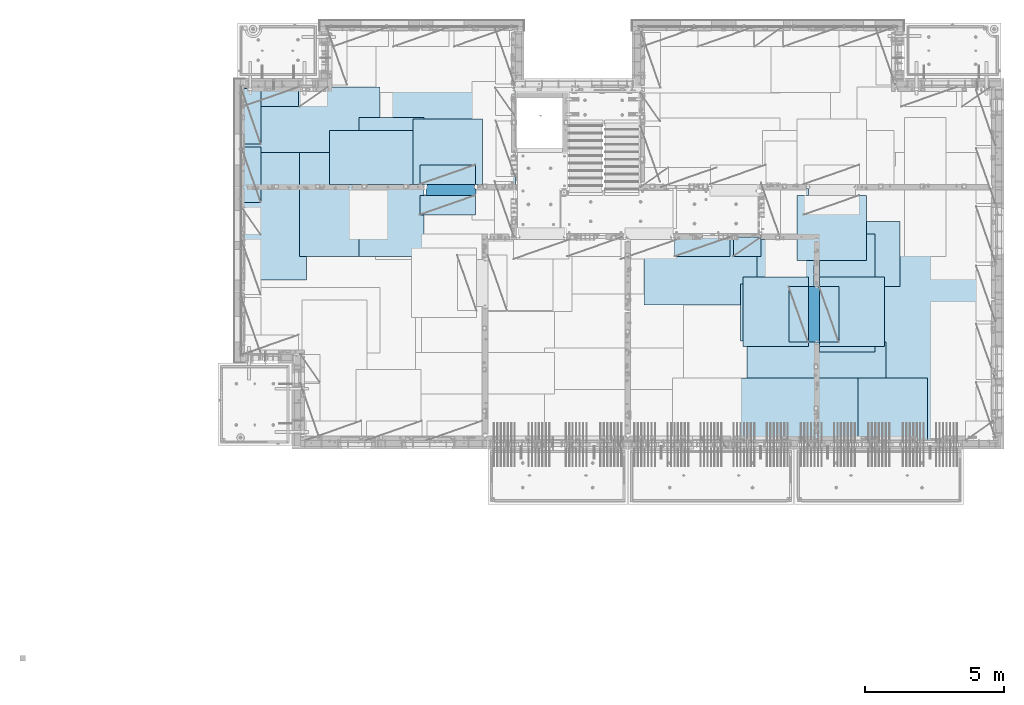
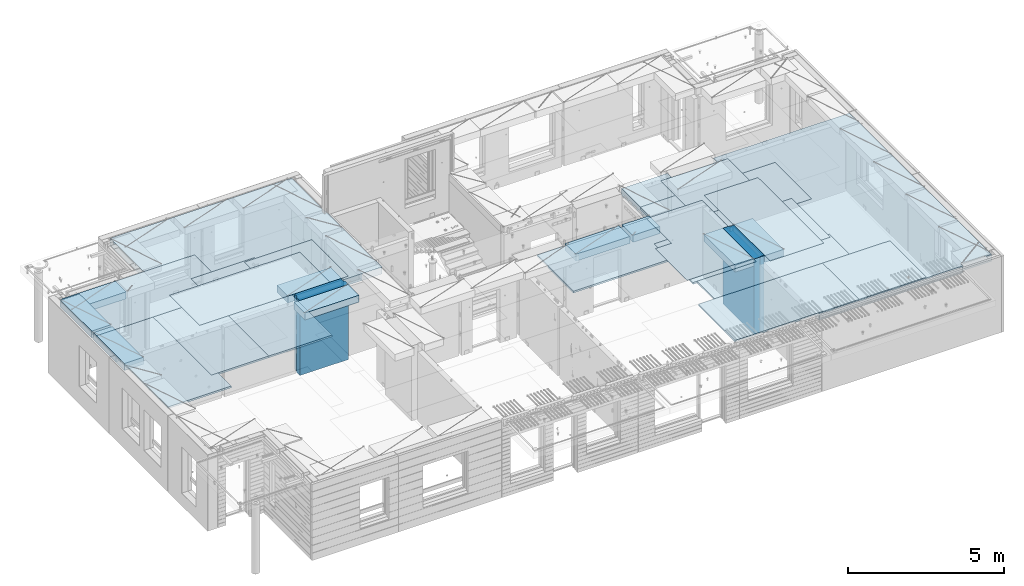
# One storey, part 204 of 349: 27 plates, 2 slabs, 25 elements without a shape of their own.
"""IFC2X3 building model written with IfcOpenShell, lengths in millimetres."""

from ifc_helpers import new_model, si_unit, frame, origin_with_axes, place, context, subcontext, project, spatial, faceted_brep, material, type_object, element, aggregate, save


model = new_model("IFC2X3")

# Units and contexts
model_context = context("Model", 3, precision=1e-05, world=origin_with_axes())
body_context = subcontext(model_context, "Body", "Model", "MODEL_VIEW")
ifc_project = project(units=[si_unit("LENGTHUNIT", "METRE", prefix="MILLI"), si_unit("AREAUNIT", "SQUARE_METRE"), si_unit("VOLUMEUNIT", "CUBIC_METRE"), si_unit("MASSUNIT", "GRAM", prefix="KILO"), si_unit("TIMEUNIT", "SECOND"), si_unit("PLANEANGLEUNIT", "RADIAN"), si_unit("SOLIDANGLEUNIT", "STERADIAN"), si_unit("THERMODYNAMICTEMPERATUREUNIT", "DEGREE_CELSIUS"), si_unit("LUMINOUSINTENSITYUNIT", "LUMEN")], contexts=[model_context])

# Site, building, storey
site_placement = place(None, origin_with_axes())
site = spatial("IfcSite", under=ifc_project, at=site_placement, CompositionType="ELEMENT")
building_placement = place(site_placement, origin_with_axes())
building = spatial("IfcBuilding", under=site, at=building_placement, CompositionType="ELEMENT")
storey_placement = place(building_placement, origin_with_axes())
storey = spatial("IfcBuildingStorey", under=building, at=storey_placement, Name="4", CompositionType="ELEMENT", Elevation=0.0)

# Assembly, slabs
assembly_1_placement = place(storey_placement, origin_with_axes())
assembly_1 = element("IfcElementAssembly", 1, at=assembly_1_placement, inside=storey, AssemblyPlace="NOTDEFINED", PredefinedType="REINFORCEMENT_UNIT")
ifc_material_1 = material(Name="CONCRETE/C30/37")
slab_type_1 = type_object("IfcSlabType", PredefinedType="NOTDEFINED")
slab_1_placement = place(assembly_1_placement, frame((7880.0, 16980.0, 93595.0), z_axis=(0.0, 1.0, 0.0), x_axis=(1.0, 0.0, 0.0)))
slab_1 = element("IfcSlab", 2, at=slab_1_placement, type_object=slab_type_1, material=ifc_material_1, PredefinedType="FLOOR", context=body_context, shape_type="Brep", body=[
    faceted_brep([(6583.68914550781, -135.0, 0.0), (6583.68914550781, 135.0, 0.0), (6583.68914550781, 135.0, 100.0), (6583.68914550781, -135.0, 100.0), (6649.99914550781, -135.0, 99.9997787475586), (6649.99914550781, 135.0, 99.9997787475586), (1.81898940354586e-12, -135.0, 1.81898940354586e-12), (-0.0001220703125, -135.0, 3600.0), (-0.0001220703125, 135.0, 3600.0), (1.81898940354586e-12, 135.0, 1.81898940354586e-12), (3110.00024414063, -135.0, 3600.0), (3110.00024414063, 135.0, 3600.0), (3110.00024414063, -135.0, 5760.0), (3110.00024414063, 135.0, 5760.0), (9850.0009765625, -135.0, 5760.0), (9850.0009765625, 135.0, 5760.0), (9850.0009765625, -135.0, 3600.0), (9850.0009765625, 135.0, 3600.0), (9870.0, -135.0, 3600.0), (9870.0, 135.0, 3600.0), (9870.0, -135.0, 0.0), (9870.0, 135.0, 0.0), (8449.99914550781, -135.0, 0.0), (8449.99914550781, 135.0, 0.0), (8449.99914550781, -135.0, 99.9997787475586), (8449.99914550781, 135.0, 99.9997787475586), (8283.68914550781, -135.0, 99.9997787475586), (8283.68914550781, 135.0, 99.9997787475586)], [[[0, 1, 2, 3]], [[4, 3, 2, 5]], [[6, 7, 8, 9]], [[7, 10, 11, 8]], [[10, 12, 13, 11]], [[12, 14, 15, 13]], [[14, 16, 17, 15]], [[16, 18, 19, 17]], [[18, 20, 21, 19]], [[21, 20, 22, 23]], [[24, 25, 23, 22]], [[26, 4, 5, 27, 25, 24]], [[1, 9, 8, 11, 13, 15, 17, 19, 21, 23, 25, 27, 5, 2]], [[6, 9, 1, 0]], [[26, 24, 22, 20, 18, 16, 14, 12, 10, 7, 6, 0, 3, 4]]]),
])
slab_type_2 = type_object("IfcSlabType", PredefinedType="NOTDEFINED")
slab_2_placement = place(assembly_1_placement, frame((28610.0, 7708.0, 93595.0), z_axis=(0.0, 1.0, 0.0), x_axis=(1.0, 0.0, 0.0)))
slab_2 = element("IfcSlab", 3, at=slab_2_placement, type_object=slab_type_2, material=ifc_material_1, PredefinedType="FLOOR", context=body_context, shape_type="Brep", body=[
    faceted_brep([(0.0, -135.0, 7430.0), (0.0, 135.0, 7430.0), (0.0, 135.0, 5722.0), (0.0, -135.0, 5722.0), (-1999.99938964844, -135.0, 7430.0), (-1999.99938964844, 135.0, 7430.0), (-1999.99938964844, -135.0, 9230.0), (-1999.99938964844, 135.0, 9230.0), (-300.000239723071, -135.0, 9230.0), (-300.000239723071, 135.0, 9230.0), (-300.00008947117, -135.0, 8972.00002930513), (-300.00008947117, 135.0, 8972.00002930513), (1385.00027673977, -135.0, 8972.00002930513), (1400.0006429507, -135.0, 8972.00002930513), (1400.0006429507, 135.0, 8972.00002930513), (1385.00027673977, 135.0, 8972.00002930513), (1400.0006429507, -135.0, 9230.0), (1400.0006429507, 135.0, 9230.0), (6449.99951171875, -135.0, 9230.0), (6449.99951171875, 135.0, 9230.0), (6449.99951171875, -135.0, 100.00023651123), (6449.99951171875, 135.0, 100.00023651123), (5318.0, -135.0, 100.0), (5318.0, 135.0, 100.0), (5318.0, -135.0, -8.68840288603678e-09), (5318.0, 135.0, -8.68840288603678e-09), (1.81898940354586e-12, -135.0, 1.81898940354586e-12), (1.81898940354586e-12, 135.0, 1.81898940354586e-12), (0.0, 135.0, 3679.99963378906), (100.00089263916, 135.0, 3679.99963378906), (100.00089263916, 135.0, 3822.0), (100.00089263916, 135.0, 5679.99963378906), (100.00089263916, 135.0, 5722.0), (100.00089263916, -135.0, 5722.0), (100.00089263916, -135.0, 3822.0), (100.00089263916, -135.0, 3679.99963378906), (0.0, -135.0, 3679.99963378906), (100.00089263916, -135.0, 5679.99963378906)], [[[0, 1, 2, 3]], [[0, 4, 5, 1]], [[4, 6, 7, 5]], [[7, 6, 8, 9]], [[8, 10, 11, 9]], [[12, 13, 14, 15, 11, 10]], [[16, 17, 14, 13]], [[18, 19, 17, 16]], [[18, 20, 21, 19]], [[20, 22, 23, 21]], [[22, 24, 25, 23]], [[24, 26, 27, 25]], [[1, 5, 7, 9, 11, 15, 14, 17, 19, 21, 23, 25, 27, 28, 29, 30, 31, 32, 2]], [[3, 2, 32, 33]], [[34, 35, 36, 26, 24, 22, 20, 18, 16, 13, 12, 10, 8, 6, 4, 0, 3, 33, 37]], [[27, 26, 36, 28]], [[35, 29, 28, 36]], [[34, 37, 31, 30, 29, 35]], [[33, 32, 31, 37]]]),
])

# Assembly, plate
assembly_2_placement = place(storey_placement, origin_with_axes())
assembly_2 = element("IfcElementAssembly", 4, at=assembly_2_placement, inside=storey, Name="Steel Assembly", AssemblyPlace="NOTDEFINED", PredefinedType="NOTDEFINED")
ifc_material_2 = material()
plate_type_1 = type_object("IfcPlateType", PredefinedType="NOTDEFINED")
plate_1_placement = place(assembly_2_placement, frame((27902.5000293051, 16680.0, 93695.1), z_axis=(1.0, 0.0, 0.0), x_axis=(0.0, -1.0, 0.0)))
plate_1 = element("IfcPlate", 5, at=plate_1_placement, type_object=plate_type_1, material=ifc_material_2, Name="1/2", context=body_context, shape_type="Brep", body=[
    faceted_brep([(0.0, -35.0, 0.0), (0.0, -35.0, 2500.0), (0.0, 35.0, 2500.0), (0.0, 35.0, 0.0), (2349.99951171875, -35.0, 2500.0), (2349.99951171875, 35.0, 2500.0), (2350.0, -35.0, 0.0), (2350.0, 35.0, 0.0)], [[[0, 1, 2, 3]], [[1, 4, 5, 2]], [[4, 6, 7, 5]], [[6, 0, 3, 7]], [[5, 7, 3, 2]], [[6, 4, 1, 0]]]),
])
aggregate(assembly_2, [plate_1])

assembly_3_placement = place(storey_placement, origin_with_axes())
assembly_3 = element("IfcElementAssembly", 6, at=assembly_3_placement, inside=storey, Name="Steel Assembly", AssemblyPlace="NOTDEFINED", PredefinedType="NOTDEFINED")
plate_2_placement = place(assembly_3_placement, frame((32610.0, 7750.0, 93695.1), z_axis=(-1.0, 3.00000001838171e-08, 0.0), x_axis=(0.0, 1.0, 0.0)))
plate_2 = element("IfcPlate", 7, at=plate_2_placement, type_object=plate_type_1, material=ifc_material_2, Name="1/2", context=body_context, shape_type="Brep", body=[
    faceted_brep([(0.0, -35.0, 0.0), (0.0, -35.0, 2500.0), (0.0, 35.0, 2500.0), (0.0, 35.0, 0.0), (2349.99951171875, -35.0, 2500.0), (2349.99951171875, 35.0, 2500.0), (2350.0, -35.0, 0.0), (2350.0, 35.0, 0.0)], [[[0, 1, 2, 3]], [[1, 4, 5, 2]], [[4, 6, 7, 5]], [[6, 0, 3, 7]], [[5, 7, 3, 2]], [[6, 4, 1, 0]]]),
])
aggregate(assembly_3, [plate_2])

assembly_4_placement = place(storey_placement, origin_with_axes())
assembly_4 = element("IfcElementAssembly", 8, at=assembly_4_placement, inside=storey, Name="Steel Assembly", AssemblyPlace="NOTDEFINED", PredefinedType="NOTDEFINED")
plate_3_placement = place(assembly_4_placement, frame((27395.0, 12730.0, 93695.1), z_axis=(-1.0, 3.00000001838171e-08, 0.0), x_axis=(0.0, 1.0, 0.0)))
plate_3 = element("IfcPlate", 9, at=plate_3_placement, type_object=plate_type_1, material=ifc_material_2, context=body_context, shape_type="Brep", body=[
    faceted_brep([(0.0, -35.0, 0.0), (0.0, -35.0, 5000.0), (0.0, 35.0, 5000.0), (0.0, 35.0, 0.0), (2349.99951171875, -35.0, 5000.0), (2349.99951171875, 35.0, 5000.0), (2350.0, -35.0, 0.0), (2350.0, 35.0, 0.0)], [[[0, 1, 2, 3]], [[1, 4, 5, 2]], [[4, 6, 7, 5]], [[6, 0, 3, 7]], [[5, 7, 3, 2]], [[6, 4, 1, 0]]]),
])
aggregate(assembly_4, [plate_3])

assembly_5_placement = place(storey_placement, origin_with_axes())
assembly_5 = element("IfcElementAssembly", 10, at=assembly_5_placement, inside=storey, Name="Steel Assembly", AssemblyPlace="NOTDEFINED", PredefinedType="NOTDEFINED")
plate_4_placement = place(assembly_5_placement, frame((28709.9995320312, 11230.0000289158, 93695.1), z_axis=(0.0, 1.0, 0.0), x_axis=(1.0, 0.0, 0.0)))
plate_4 = element("IfcPlate", 11, at=plate_4_placement, type_object=plate_type_1, material=ifc_material_2, Name="1/2", context=body_context, shape_type="Brep", body=[
    faceted_brep([(0.0, -35.0, 0.0), (0.0, -35.0, 2500.0), (0.0, 35.0, 2500.0), (0.0, 35.0, 0.0), (2349.99951171875, -35.0, 2500.0), (2349.99951171875, 35.0, 2500.0), (2350.0, -35.0, 0.0), (2350.0, 35.0, 0.0)], [[[0, 1, 2, 3]], [[1, 4, 5, 2]], [[4, 6, 7, 5]], [[6, 0, 3, 7]], [[5, 7, 3, 2]], [[6, 4, 1, 0]]]),
])
aggregate(assembly_5, [plate_4])

assembly_6_placement = place(storey_placement, origin_with_axes())
assembly_6 = element("IfcElementAssembly", 12, at=assembly_6_placement, inside=storey, Name="Steel Assembly", AssemblyPlace="NOTDEFINED", PredefinedType="NOTDEFINED")
plate_5_placement = place(assembly_6_placement, frame((25959.9995320312, 11230.0000289158, 93695.1), z_axis=(0.0, 1.0, 0.0), x_axis=(1.0, 0.0, 0.0)))
plate_5 = element("IfcPlate", 13, at=plate_5_placement, type_object=plate_type_1, material=ifc_material_2, Name="1/2", context=body_context, shape_type="Brep", body=[
    faceted_brep([(0.0, -35.0, 0.0), (0.0, -35.0, 2500.0), (0.0, 35.0, 2500.0), (0.0, 35.0, 0.0), (2349.99951171875, -35.0, 2500.0), (2349.99951171875, 35.0, 2500.0), (2350.0, -35.0, 0.0), (2350.0, 35.0, 0.0)], [[[0, 1, 2, 3]], [[1, 4, 5, 2]], [[4, 6, 7, 5]], [[6, 0, 3, 7]], [[5, 7, 3, 2]], [[6, 4, 1, 0]]]),
])
aggregate(assembly_6, [plate_5])

assembly_7_placement = place(storey_placement, origin_with_axes())
assembly_7 = element("IfcElementAssembly", 14, at=assembly_7_placement, inside=storey, Name="Steel Assembly", AssemblyPlace="NOTDEFINED", PredefinedType="NOTDEFINED")
plate_6_placement = place(assembly_7_placement, frame((7880.0, 20580.0, 93695.1), z_axis=(1.0, 0.0, 0.0), x_axis=(0.0, -1.0, 0.0)))
plate_6 = element("IfcPlate", 15, at=plate_6_placement, type_object=plate_type_1, material=ifc_material_2, context=body_context, shape_type="Brep", body=[
    faceted_brep([(0.0, -35.0, 0.0), (0.0, -35.0, 5000.0), (0.0, 35.0, 5000.0), (0.0, 35.0, 0.0), (2349.99951171875, -35.0, 5000.0), (2349.99951171875, 35.0, 5000.0), (2350.0, -35.0, 0.0), (2350.0, 35.0, 0.0)], [[[0, 1, 2, 3]], [[1, 4, 5, 2]], [[4, 6, 7, 5]], [[6, 0, 3, 7]], [[5, 7, 3, 2]], [[6, 4, 1, 0]]]),
])
aggregate(assembly_7, [plate_6])

assembly_8_placement = place(storey_placement, origin_with_axes())
assembly_8 = element("IfcElementAssembly", 16, at=assembly_8_placement, inside=storey, Name="Steel Assembly", AssemblyPlace="NOTDEFINED", PredefinedType="NOTDEFINED")
plate_7_placement = place(assembly_8_placement, frame((14063.69, 19430.0, 93695.1), z_axis=(1.0, 0.0, 0.0), x_axis=(0.0, -1.0, 0.0)))
plate_7 = element("IfcPlate", 17, at=plate_7_placement, type_object=plate_type_1, material=ifc_material_2, Name="1/2", context=body_context, shape_type="Brep", body=[
    faceted_brep([(0.0, -35.0, 0.0), (0.0, -35.0, 2500.0), (0.0, 35.0, 2500.0), (0.0, 35.0, 0.0), (2349.99951171875, -35.0, 2500.0), (2349.99951171875, 35.0, 2500.0), (2350.0, -35.0, 0.0), (2350.0, 35.0, 0.0)], [[[0, 1, 2, 3]], [[1, 4, 5, 2]], [[4, 6, 7, 5]], [[6, 0, 3, 7]], [[5, 7, 3, 2]], [[6, 4, 1, 0]]]),
])
aggregate(assembly_8, [plate_7])

assembly_9_placement = place(storey_placement, origin_with_axes())
assembly_9 = element("IfcElementAssembly", 18, at=assembly_9_placement, inside=storey, Name="Steel Assembly", AssemblyPlace="NOTDEFINED", PredefinedType="NOTDEFINED")
plate_8_placement = place(assembly_9_placement, frame((31610.0, 13388.0, 93695.1), z_axis=(-1.0, 3.00000001838171e-08, 0.0), x_axis=(0.0, 1.0, 0.0)))
plate_8 = element("IfcPlate", 19, at=plate_8_placement, type_object=plate_type_1, material=ifc_material_2, context=body_context, shape_type="Brep", body=[
    faceted_brep([(0.0, -35.0, 0.0), (0.0, -35.0, 5000.0), (0.0, 35.0, 5000.0), (0.0, 35.0, 0.0), (2349.99951171875, -35.0, 5000.0), (2349.99951171875, 35.0, 5000.0), (2350.0, -35.0, 0.0), (2350.0, 35.0, 0.0)], [[[0, 1, 2, 3]], [[1, 4, 5, 2]], [[4, 6, 7, 5]], [[6, 0, 3, 7]], [[5, 7, 3, 2]], [[6, 4, 1, 0]]]),
])
aggregate(assembly_9, [plate_8])

assembly_10_placement = place(storey_placement, origin_with_axes())
assembly_10 = element("IfcElementAssembly", 20, at=assembly_10_placement, inside=storey, Name="Steel Assembly", AssemblyPlace="NOTDEFINED", PredefinedType="NOTDEFINED")
plate_9_placement = place(assembly_10_placement, frame((31110.0, 9038.0, 93695.1), z_axis=(-1.0, 3.00000001838171e-08, 0.0), x_axis=(0.0, 1.0, 0.0)))
plate_9 = element("IfcPlate", 21, at=plate_9_placement, type_object=plate_type_1, material=ifc_material_2, context=body_context, shape_type="Brep", body=[
    faceted_brep([(0.0, -35.0, 0.0), (0.0, -35.0, 5000.0), (0.0, 35.0, 5000.0), (0.0, 35.0, 0.0), (2349.99951171875, -35.0, 5000.0), (2349.99951171875, 35.0, 5000.0), (2350.0, -35.0, 0.0), (2350.0, 35.0, 0.0)], [[[0, 1, 2, 3]], [[1, 4, 5, 2]], [[4, 6, 7, 5]], [[6, 0, 3, 7]], [[5, 7, 3, 2]], [[6, 4, 1, 0]]]),
])
aggregate(assembly_10, [plate_9])

assembly_11_placement = place(storey_placement, origin_with_axes())
assembly_11 = element("IfcElementAssembly", 22, at=assembly_11_placement, inside=storey, Name="Steel Assembly", AssemblyPlace="NOTDEFINED", PredefinedType="NOTDEFINED")
plate_10_placement = place(assembly_11_placement, frame((30510.0, 7750.0, 93695.1), z_axis=(-1.0, 3.00000001838171e-08, 0.0), x_axis=(0.0, 1.0, 0.0)))
plate_10 = element("IfcPlate", 23, at=plate_10_placement, type_object=plate_type_1, material=ifc_material_2, context=body_context, shape_type="Brep", body=[
    faceted_brep([(0.0, -35.0, 0.0), (0.0, -35.0, 5000.0), (0.0, 35.0, 5000.0), (0.0, 35.0, 0.0), (2349.99951171875, -35.0, 5000.0), (2349.99951171875, 35.0, 5000.0), (2350.0, -35.0, 0.0), (2350.0, 35.0, 0.0)], [[[0, 1, 2, 3]], [[1, 4, 5, 2]], [[4, 6, 7, 5]], [[6, 0, 3, 7]], [[5, 7, 3, 2]], [[6, 4, 1, 0]]]),
])
aggregate(assembly_11, [plate_10])

assembly_12_placement = place(storey_placement, origin_with_axes())
assembly_12 = element("IfcElementAssembly", 24, at=assembly_12_placement, inside=storey, Name="Steel Assembly", AssemblyPlace="NOTDEFINED", PredefinedType="NOTDEFINED")
plate_11_placement = place(assembly_12_placement, frame((10230.0, 18627.0, 93695.1), z_axis=(0.0, -1.0, 0.0), x_axis=(-1.0, 3.00000001838171e-08, 0.0)))
plate_11 = element("IfcPlate", 25, at=plate_11_placement, type_object=plate_type_1, material=ifc_material_2, context=body_context, shape_type="Brep", body=[
    faceted_brep([(0.0, -35.0, 0.0), (0.0, -35.0, 5000.0), (0.0, 35.0, 5000.0), (0.0, 35.0, 0.0), (2349.99951171875, -35.0, 5000.0), (2349.99951171875, 35.0, 5000.0), (2350.0, -35.0, 0.0), (2350.0, 35.0, 0.0)], [[[0, 1, 2, 3]], [[1, 4, 5, 2]], [[4, 6, 7, 5]], [[6, 0, 3, 7]], [[5, 7, 3, 2]], [[6, 4, 1, 0]]]),
])
aggregate(assembly_12, [plate_11])

assembly_13_placement = place(storey_placement, origin_with_axes())
assembly_13 = element("IfcElementAssembly", 26, at=assembly_13_placement, inside=storey, Name="Steel Assembly", AssemblyPlace="NOTDEFINED", PredefinedType="NOTDEFINED")
plate_12_placement = place(assembly_13_placement, frame((14463.69, 19480.0, 93695.1), z_axis=(0.0, -1.0, 0.0), x_axis=(-1.0, 3.00000001838171e-08, 0.0)))
plate_12 = element("IfcPlate", 27, at=plate_12_placement, type_object=plate_type_1, material=ifc_material_2, context=body_context, shape_type="Brep", body=[
    faceted_brep([(0.0, -35.0, 0.0), (0.0, -35.0, 5000.0), (0.0, 35.0, 5000.0), (0.0, 35.0, 0.0), (2349.99951171875, -35.0, 5000.0), (2349.99951171875, 35.0, 5000.0), (2350.0, -35.0, 0.0), (2350.0, 35.0, 0.0)], [[[0, 1, 2, 3]], [[1, 4, 5, 2]], [[4, 6, 7, 5]], [[6, 0, 3, 7]], [[5, 7, 3, 2]], [[6, 4, 1, 0]]]),
])
aggregate(assembly_13, [plate_12])

assembly_14_placement = place(storey_placement, origin_with_axes())
assembly_14 = element("IfcElementAssembly", 28, at=assembly_14_placement, inside=storey, Name="Steel Assembly", AssemblyPlace="NOTDEFINED", PredefinedType="NOTDEFINED")
plate_13_placement = place(assembly_14_placement, frame((12330.0, 19480.0, 93695.1), z_axis=(0.0, -1.0, 0.0), x_axis=(-1.0, 3.00000001838171e-08, 0.0)))
plate_13 = element("IfcPlate", 29, at=plate_13_placement, type_object=plate_type_1, material=ifc_material_2, context=body_context, shape_type="Brep", body=[
    faceted_brep([(0.0, -35.0, 0.0), (0.0, -35.0, 5000.0), (0.0, 35.0, 5000.0), (0.0, 35.0, 0.0), (2349.99951171875, -35.0, 5000.0), (2349.99951171875, 35.0, 5000.0), (2350.0, -35.0, 0.0), (2350.0, 35.0, 0.0)], [[[0, 1, 2, 3]], [[1, 4, 5, 2]], [[4, 6, 7, 5]], [[6, 0, 3, 7]], [[5, 7, 3, 2]], [[6, 4, 1, 0]]]),
])
aggregate(assembly_14, [plate_13])

assembly_15_placement = place(storey_placement, origin_with_axes())
assembly_15 = element("IfcElementAssembly", 30, at=assembly_15_placement, inside=storey, Name="Steel Assembly", AssemblyPlace="NOTDEFINED", PredefinedType="NOTDEFINED")
plate_type_2 = type_object("IfcPlateType", PredefinedType="NOTDEFINED")
plate_14_placement = place(assembly_15_placement, frame((7879.99987792969, 20530.0, 93595.3), z_axis=(1.0, 0.0, 0.0), x_axis=(0.0, -1.0, 0.0)))
plate_14 = element("IfcPlate", 31, at=plate_14_placement, type_object=plate_type_2, material=ifc_material_2, Name="RE1", context=body_context, shape_type="Brep", body=[
    faceted_brep([(1.81898940354586e-12, -135.0, 1.81898940354586e-12), (0.0, -135.0, 699.999999999996), (0.0, 135.0, 699.999999999996), (1.81898940354586e-12, 135.0, 1.81898940354586e-12), (1999.99951171875, -135.0, 699.999999999993), (1999.99951171875, 135.0, 699.999999999993), (2000.0, -135.0, -3.63797880709171e-12), (2000.0, 135.0, -3.63797880709171e-12)], [[[0, 1, 2, 3]], [[1, 4, 5, 2]], [[4, 6, 7, 5]], [[6, 0, 3, 7]], [[5, 7, 3, 2]], [[6, 4, 1, 0]]]),
])
aggregate(assembly_15, [plate_14])

assembly_16_placement = place(storey_placement, origin_with_axes())
assembly_16 = element("IfcElementAssembly", 32, at=assembly_16_placement, inside=storey, Name="Steel Assembly", AssemblyPlace="NOTDEFINED", PredefinedType="NOTDEFINED")
plate_15_placement = place(assembly_16_placement, frame((28710.2298779297, 13388.0, 93595.3), z_axis=(1.0, 0.0, 0.0), x_axis=(0.0, -1.0, 0.0)))
plate_15 = element("IfcPlate", 33, at=plate_15_placement, type_object=plate_type_2, material=ifc_material_2, Name="RE1", context=body_context, shape_type="Brep", body=[
    faceted_brep([(1.81898940354586e-12, -135.0, 1.81898940354586e-12), (0.0, -135.0, 699.999999999996), (0.0, 135.0, 699.999999999996), (1.81898940354586e-12, 135.0, 1.81898940354586e-12), (1999.99951171875, -135.0, 699.999999999993), (1999.99951171875, 135.0, 699.999999999993), (2000.0, -135.0, -3.63797880709171e-12), (2000.0, 135.0, -3.63797880709171e-12)], [[[0, 1, 2, 3]], [[1, 4, 5, 2]], [[4, 6, 7, 5]], [[6, 0, 3, 7]], [[5, 7, 3, 2]], [[6, 4, 1, 0]]]),
])
aggregate(assembly_16, [plate_15])

assembly_17_placement = place(storey_placement, origin_with_axes())
assembly_17 = element("IfcElementAssembly", 34, at=assembly_17_placement, inside=storey, Name="Steel Assembly", AssemblyPlace="NOTDEFINED", PredefinedType="NOTDEFINED")
plate_16_placement = place(assembly_17_placement, frame((28310.0001220703, 11388.0, 93595.3), z_axis=(-1.0, 3.00000001838171e-08, 0.0), x_axis=(0.0, 1.0, 0.0)))
plate_16 = element("IfcPlate", 35, at=plate_16_placement, type_object=plate_type_2, material=ifc_material_2, Name="RE1", context=body_context, shape_type="Brep", body=[
    faceted_brep([(1.81898940354586e-12, -135.0, 1.81898940354586e-12), (0.0, -135.0, 699.999999999996), (0.0, 135.0, 699.999999999996), (1.81898940354586e-12, 135.0, 1.81898940354586e-12), (1999.99951171875, -135.0, 699.999999999993), (1999.99951171875, 135.0, 699.999999999993), (2000.0, -135.0, -3.63797880709171e-12), (2000.0, 135.0, -3.63797880709171e-12)], [[[0, 1, 2, 3]], [[1, 4, 5, 2]], [[4, 6, 7, 5]], [[6, 0, 3, 7]], [[5, 7, 3, 2]], [[6, 4, 1, 0]]]),
])
aggregate(assembly_17, [plate_16])

assembly_18_placement = place(storey_placement, origin_with_axes())
assembly_18 = element("IfcElementAssembly", 36, at=assembly_18_placement, inside=storey, Name="Steel Assembly", AssemblyPlace="NOTDEFINED", PredefinedType="NOTDEFINED")
plate_17_placement = place(assembly_18_placement, frame((14313.6908542386, 17080.0001036336, 93595.3), z_axis=(0.0, 1.0, 0.0), x_axis=(1.0, 0.0, 0.0)))
plate_17 = element("IfcPlate", 37, at=plate_17_placement, type_object=plate_type_2, material=ifc_material_2, Name="RE1", context=body_context, shape_type="Brep", body=[
    faceted_brep([(1.81898940354586e-12, -135.0, 1.81898940354586e-12), (0.0, -135.0, 699.999999999996), (0.0, 135.0, 699.999999999996), (1.81898940354586e-12, 135.0, 1.81898940354586e-12), (1999.99951171875, -135.0, 699.999999999993), (1999.99951171875, 135.0, 699.999999999993), (2000.0, -135.0, -3.63797880709171e-12), (2000.0, 135.0, -3.63797880709171e-12)], [[[0, 1, 2, 3]], [[1, 4, 5, 2]], [[4, 6, 7, 5]], [[6, 0, 3, 7]], [[5, 7, 3, 2]], [[6, 4, 1, 0]]]),
])
aggregate(assembly_18, [plate_17])

assembly_19_placement = place(storey_placement, origin_with_axes())
assembly_19 = element("IfcElementAssembly", 38, at=assembly_19_placement, inside=storey, Name="Steel Assembly", AssemblyPlace="NOTDEFINED", PredefinedType="NOTDEFINED")
plate_18_placement = place(assembly_19_placement, frame((16313.6891457614, 16679.9998963664, 93595.3), z_axis=(0.0, -1.0, 0.0), x_axis=(-1.0, 3.00000001838171e-08, 0.0)))
plate_18 = element("IfcPlate", 39, at=plate_18_placement, type_object=plate_type_2, material=ifc_material_2, Name="RE1", context=body_context, shape_type="Brep", body=[
    faceted_brep([(1.81898940354586e-12, -135.0, 1.81898940354586e-12), (0.0, -135.0, 699.999999999996), (0.0, 135.0, 699.999999999996), (1.81898940354586e-12, 135.0, 1.81898940354586e-12), (1999.99951171875, -135.0, 699.999999999993), (1999.99951171875, 135.0, 699.999999999993), (2000.0, -135.0, -3.63797880709171e-12), (2000.0, 135.0, -3.63797880709171e-12)], [[[0, 1, 2, 3]], [[1, 4, 5, 2]], [[4, 6, 7, 5]], [[6, 0, 3, 7]], [[5, 7, 3, 2]], [[6, 4, 1, 0]]]),
])
aggregate(assembly_19, [plate_18])

assembly_20_placement = place(storey_placement, origin_with_axes())
assembly_20 = element("IfcElementAssembly", 40, at=assembly_20_placement, inside=storey, Name="Steel Assembly", AssemblyPlace="NOTDEFINED", PredefinedType="NOTDEFINED")
plate_19_placement = place(assembly_20_placement, frame((25494.9991457614, 15179.9998963664, 93595.3), z_axis=(0.0, -1.0, 0.0), x_axis=(-1.0, 3.00000001838171e-08, 0.0)))
plate_19 = element("IfcPlate", 41, at=plate_19_placement, type_object=plate_type_2, material=ifc_material_2, Name="RE1", context=body_context, shape_type="Brep", body=[
    faceted_brep([(1.81898940354586e-12, -135.0, 1.81898940354586e-12), (0.0, -135.0, 699.999999999996), (0.0, 135.0, 699.999999999996), (1.81898940354586e-12, 135.0, 1.81898940354586e-12), (1999.99951171875, -135.0, 699.999999999993), (1999.99951171875, 135.0, 699.999999999993), (2000.0, -135.0, -3.63797880709171e-12), (2000.0, 135.0, -3.63797880709171e-12)], [[[0, 1, 2, 3]], [[1, 4, 5, 2]], [[4, 6, 7, 5]], [[6, 0, 3, 7]], [[5, 7, 3, 2]], [[6, 4, 1, 0]]]),
])
aggregate(assembly_20, [plate_19])

assembly_21_placement = place(storey_placement, origin_with_axes())
assembly_21 = element("IfcElementAssembly", 42, at=assembly_21_placement, inside=storey, Name="Steel Assembly", AssemblyPlace="NOTDEFINED", PredefinedType="NOTDEFINED")
plate_20_placement = place(assembly_21_placement, frame((26610.0, 15180.0000000707, 93595.3), z_axis=(0.0, -1.0, 0.0), x_axis=(-1.0, 3.00000001838171e-08, 0.0)))
plate_20 = element("IfcPlate", 43, at=plate_20_placement, type_object=plate_type_2, material=ifc_material_2, Name="RE1_1/2", context=body_context, shape_type="Brep", body=[
    faceted_brep([(1.81898940354586e-12, -135.0, 1.81898940354586e-12), (0.0, -135.0, 699.999999999996), (0.0, 135.0, 699.999999999996), (1.81898940354586e-12, 135.0, 1.81898940354586e-12), (999.99951171875, -135.0, 700.0), (999.99951171875, 135.0, 700.0), (1000.0, -135.0, 0.0), (1000.0, 135.0, 0.0)], [[[0, 1, 2, 3]], [[1, 4, 5, 2]], [[4, 6, 7, 5]], [[6, 0, 3, 7]], [[5, 7, 3, 2]], [[6, 4, 1, 0]]]),
])
aggregate(assembly_21, [plate_20])

assembly_22_placement = place(storey_placement, origin_with_axes())
assembly_22 = element("IfcElementAssembly", 44, at=assembly_22_placement, inside=storey, Name="Steel Assembly", AssemblyPlace="NOTDEFINED", PredefinedType="NOTDEFINED")
plate_21_placement = place(assembly_22_placement, frame((9935.0, 20580.0001220703, 93595.3), z_axis=(0.0, -1.0, 0.0), x_axis=(-1.0, 3.00000001838171e-08, 0.0)))
plate_21 = element("IfcPlate", 45, at=plate_21_placement, type_object=plate_type_2, material=ifc_material_2, Name="RE1", context=body_context, shape_type="Brep", body=[
    faceted_brep([(1.81898940354586e-12, -135.0, 1.81898940354586e-12), (0.0, -135.0, 699.999999999996), (0.0, 135.0, 699.999999999996), (1.81898940354586e-12, 135.0, 1.81898940354586e-12), (1999.99951171875, -135.0, 699.999999999993), (1999.99951171875, 135.0, 699.999999999993), (2000.0, -135.0, -3.63797880709171e-12), (2000.0, 135.0, -3.63797880709171e-12)], [[[0, 1, 2, 3]], [[1, 4, 5, 2]], [[4, 6, 7, 5]], [[6, 0, 3, 7]], [[5, 7, 3, 2]], [[6, 4, 1, 0]]]),
])
aggregate(assembly_22, [plate_21])

assembly_23_placement = place(storey_placement, origin_with_axes())
assembly_23 = element("IfcElementAssembly", 46, at=assembly_23_placement, inside=storey, Name="Steel Assembly", AssemblyPlace="NOTDEFINED", PredefinedType="NOTDEFINED")
plate_22_placement = place(assembly_23_placement, frame((7879.99987792969, 18430.0, 93595.3), z_axis=(1.0, 0.0, 0.0), x_axis=(0.0, -1.0, 0.0)))
plate_22 = element("IfcPlate", 47, at=plate_22_placement, type_object=plate_type_2, material=ifc_material_2, Name="RE1", context=body_context, shape_type="Brep", body=[
    faceted_brep([(1.81898940354586e-12, -135.0, 1.81898940354586e-12), (0.0, -135.0, 699.999999999996), (0.0, 135.0, 699.999999999996), (1.81898940354586e-12, 135.0, 1.81898940354586e-12), (1999.99951171875, -135.0, 699.999999999993), (1999.99951171875, 135.0, 699.999999999993), (2000.0, -135.0, -3.63797880709171e-12), (2000.0, 135.0, -3.63797880709171e-12)], [[[0, 1, 2, 3]], [[1, 4, 5, 2]], [[4, 6, 7, 5]], [[6, 0, 3, 7]], [[5, 7, 3, 2]], [[6, 4, 1, 0]]]),
])
aggregate(assembly_23, [plate_22])

# Plate
plate_type_3 = type_object("IfcPlateType", PredefinedType="NOTDEFINED")
plate_23_placement = place(assembly_1_placement, frame((11048.0003525539, 17079.9997757405, 93725.45), z_axis=(0.0, 1.0, 0.0), x_axis=(1.0, 0.0, 0.0)))
plate_23 = element("IfcPlate", 48, at=plate_23_placement, type_object=plate_type_3, material=ifc_material_2, context=body_context, shape_type="Brep", body=[
    faceted_brep([(0.0, -5.0, 0.0), (0.0, -5.0, 1939.99963378906), (0.0, 5.0, 1939.99963378906), (0.0, 5.0, 0.0), (4827.9990234375, -5.0, 1939.99963378906), (4827.9990234375, 5.0, 1939.99963378906), (4827.9990234375, -5.0, 0.0), (4827.9990234375, 5.0, 0.0)], [[[0, 1, 2, 3]], [[1, 4, 5, 2]], [[4, 6, 7, 5]], [[6, 0, 3, 7]], [[5, 7, 3, 2]], [[6, 4, 1, 0]]]),
])

plate_type_4 = type_object("IfcPlateType", PredefinedType="NOTDEFINED")
plate_24_placement = place(assembly_1_placement, frame((28710.0010086818, 11039.9998138874, 93725.45), z_axis=(0.0, 1.0, 0.0), x_axis=(1.0, 0.0, 0.0)))
plate_24 = element("IfcPlate", 49, at=plate_24_placement, type_object=plate_type_4, material=ifc_material_2, context=body_context, shape_type="Brep", body=[
    faceted_brep([(0.0, -5.0, 0.0), (-0.00100868183653802, -5.0, 4240.0), (-0.00100868183653802, 5.0, 4240.0), (0.0, 5.0, 0.0), (2000.0, -5.0, 4240.0), (2000.0, 5.0, 4240.0), (2000.0, -5.0, 0.0), (2000.0, 5.0, 0.0)], [[[0, 1, 2, 3]], [[1, 4, 5, 2]], [[4, 6, 7, 5]], [[6, 0, 3, 7]], [[5, 7, 3, 2]], [[6, 4, 1, 0]]]),
])

plate_type_5 = type_object("IfcPlateType", PredefinedType="NOTDEFINED")
plate_25_placement = place(assembly_1_placement, frame((25860.0006272121, 11525.9998749226, 93725.45), z_axis=(1.0, 0.0, 0.0), x_axis=(0.0, -1.0, 0.0)))
plate_25 = element("IfcPlate", 50, at=plate_25_placement, type_object=plate_type_5, material=ifc_material_2, context=body_context, shape_type="Brep", body=[
    faceted_brep([(92.0000076293945, -5.0, 2449.99937278789), (92.0000076293945, 5.0, 2449.99937278789), (-1861.99975886647, 5.0, 2449.99937278789), (-1861.99975886647, -5.0, 2449.99937278789), (-1861.99975886647, -5.0, 2649.99937278789), (-1861.99975886647, 5.0, 2649.99939842034), (92.0000076293945, -5.0, 0.0), (0.0, -5.0, 0.0), (0.0, 5.0, 0.0), (92.0000076293945, 5.0, 0.0), (-1954.00048828125, -5.0, 0.0), (-1954.00048828125, 5.0, 0.0), (-1954.00048828125, -5.0, 600.000366210938), (-1954.00048828125, 5.0, 600.000366210938), (-3554.0, -5.0, 600.000366210938), (-3554.0, 5.0, 600.000366210938), (-3554.0, -5.0, 2649.99951171875), (-3554.0, 5.0, 2649.99951171875)], [[[0, 1, 2, 3]], [[4, 3, 2, 5]], [[6, 7, 8, 9]], [[7, 10, 11, 8]], [[10, 12, 13, 11]], [[12, 14, 15, 13]], [[14, 16, 17, 15]], [[17, 16, 4, 5]], [[1, 9, 8, 11, 13, 15, 17, 5, 2]], [[6, 9, 1, 0]], [[16, 14, 12, 10, 7, 6, 0, 3, 4]]]),
])

aggregate(assembly_1, [plate_24, plate_25, plate_23, slab_2, slab_1])

# Assembly, plate
assembly_24_placement = place(storey_placement, origin_with_axes())
assembly_24 = element("IfcElementAssembly", 51, at=assembly_24_placement, inside=storey, Name="Steel Assembly", AssemblyPlace="NOTDEFINED", PredefinedType="NOTDEFINED")
ifc_material_3 = material()
plate_type_6 = type_object("IfcPlateType", PredefinedType="NOTDEFINED")
plate_26_placement = place(assembly_24_placement, frame((14530.0, 16680.0, 92255.6000003815), z_axis=(0.0, 1.0, 0.0), x_axis=(1.0, 0.0, 0.0)))
plate_26 = element("IfcPlate", 52, at=plate_26_placement, type_object=plate_type_6, material=ifc_material_3, context=body_context, shape_type="Brep", body=[
    faceted_brep([(1749.99914550781, -1475.0, 400.0), (1749.99914550781, -1475.0, 243.000000000004), (1749.99914550781, 1475.0, 243.000000000004), (1749.99914550781, 1475.0, 400.0), (1799.99914550781, -1475.0, 221.333333333332), (1799.99914550781, 1475.0, 221.333333333332), (30.0, -1475.0, 400.0), (30.0, 1475.0, 400.0), (30.0, 1475.0, 243.0), (30.0, -1475.0, 243.0), (0.0, 1475.0, 230.0), (0.0, -1475.0, 230.0), (0.0, 1475.0, 0.0), (0.0, -1475.0, 0.0), (1799.99914550781, -1475.0, 3.63797880709171e-12), (1799.99914550781, 1475.0, 3.63797880709171e-12)], [[[0, 1, 2, 3]], [[4, 5, 2, 1]], [[6, 7, 8, 9]], [[9, 8, 10, 11]], [[12, 13, 11, 10]], [[14, 13, 12, 15]], [[0, 6, 9, 11, 13, 14, 4, 1]], [[7, 6, 0, 3]], [[15, 12, 10, 8, 7, 3, 2, 5]], [[14, 15, 5, 4]]]),
])
aggregate(assembly_24, [plate_26])

assembly_25_placement = place(storey_placement, origin_with_axes())
assembly_25 = element("IfcElementAssembly", 53, at=assembly_25_placement, inside=storey, Name="Steel Assembly", AssemblyPlace="NOTDEFINED", PredefinedType="NOTDEFINED")
plate_27_placement = place(assembly_25_placement, frame((28710.0, 11388.0, 92255.6000003815), z_axis=(-1.0, 3.00000001838171e-08, 0.0), x_axis=(0.0, 1.0, 0.0)))
plate_27 = element("IfcPlate", 54, at=plate_27_placement, type_object=plate_type_6, material=ifc_material_3, context=body_context, shape_type="Brep", body=[
    faceted_brep([(0.0, -1475.0, 170.000000230655), (0.0, 1475.0, 170.000000368096), (30.0, 1475.0, 156.999999999998), (30.0, -1475.0, 156.999999999998), (29.9999998430139, -1475.0, 0.0), (29.9999998430139, 1475.0, 0.0), (0.0, -1475.0, 400.0), (1999.99963378906, -1475.0, 400.0), (1999.99963378906, 1475.0, 400.0), (0.0, 1475.0, 400.0), (1999.99963378906, -1475.0, 170.000003831468), (1999.99963378906, 1475.0, 170.000003831468), (1969.99962494722, -1475.0, 157.0), (1969.99962494722, 1475.0, 157.0), (1969.99962494722, -1475.0, 0.0), (1969.99962494722, 1475.0, 0.0)], [[[0, 1, 2, 3]], [[4, 3, 2, 5]], [[6, 7, 8, 9]], [[8, 7, 10, 11]], [[12, 13, 11, 10]], [[14, 15, 13, 12]], [[15, 14, 4, 5]], [[1, 9, 8, 11, 13, 15, 5, 2]], [[6, 9, 1, 0]], [[14, 12, 10, 7, 6, 0, 3, 4]]]),
])
aggregate(assembly_25, [plate_27])

save(model, "model.ifc")
